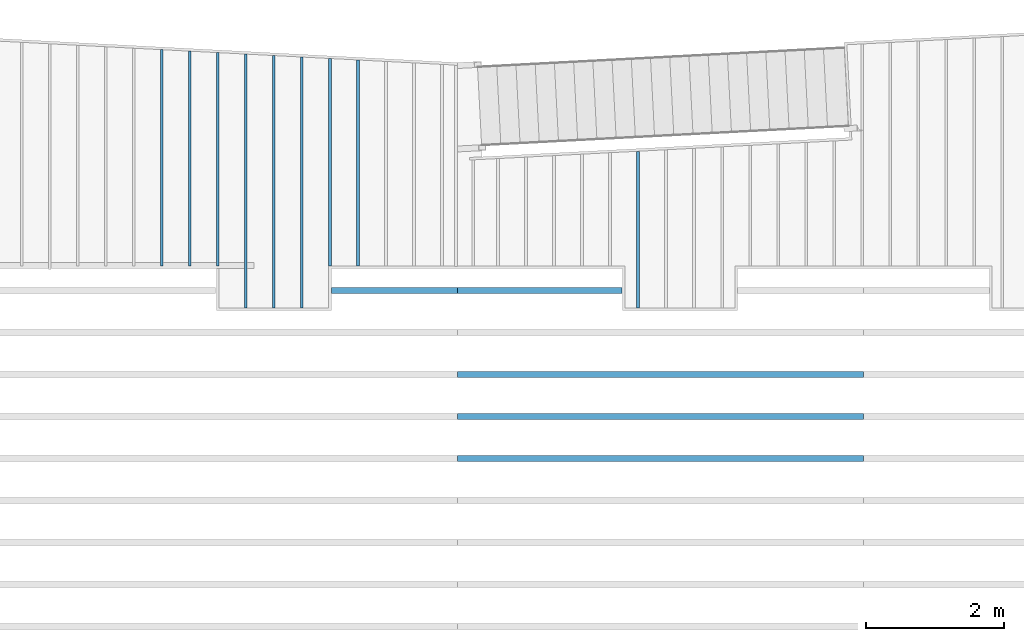
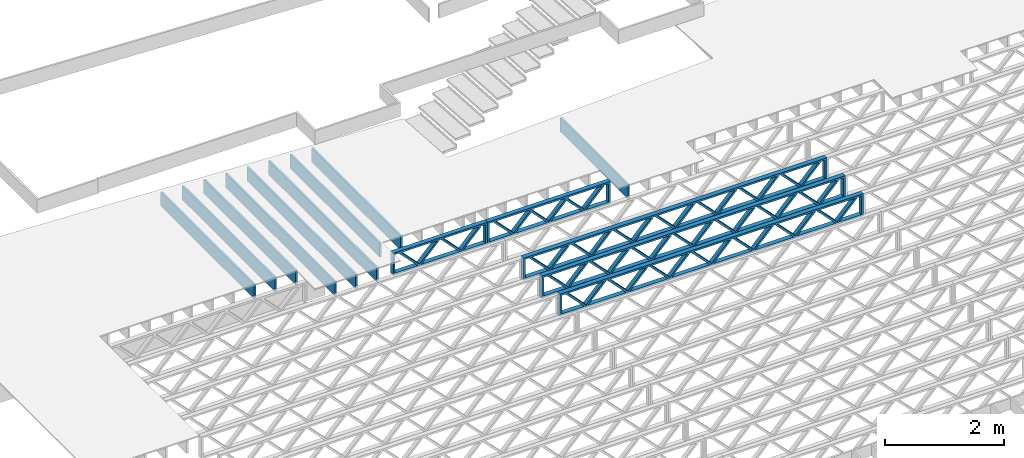
# One storey, part 4 of 23: 14 beams, 3 elements without a shape of their own.
"""IFC4 building model written with IfcOpenShell, lengths in feet."""

import ifcopenshell
import ifcopenshell.guid

model = None  # the IFC model being written
_history = None  # IfcOwnerHistory: only IFC2X3 demands one
_inside = {}  # id of a spatial element -> (the spatial element, [elements in it])
_under = {}  # id of a project, library or spatial element -> (it, [spatial elements below it])
_declared = {}  # id of a project -> (the project, [libraries it declares])
_typed = {}  # id of a type object -> (the type object, [elements of that type])
_made_of = {}  # id of a material, layer set ... -> (it, [elements and type objects made of it])


def new_model(schema):
    """Start an empty IFC model of exactly this schema.

    Asked for "IFC4X3", IfcOpenShell would pick the latest addendum, in which some entities
    have other attributes; the version numbers below select the first issue.
    IFC2X3 requires an IfcOwnerHistory on every rooted entity: one is made here for all.
    """
    global model, _history
    if schema == "IFC4X3":
        model = ifcopenshell.file(schema_version=(4, 3, 0, 0))
    else:
        model = ifcopenshell.file(schema=schema)
    _inside.clear()
    _under.clear()
    _declared.clear()
    _typed.clear()
    _made_of.clear()
    _history = None
    if model.schema == "IFC2X3":
        org = make("IfcOrganization", Name="unknown")
        user = make(
            "IfcPersonAndOrganization",
            ThePerson=make("IfcPerson", FamilyName="unknown"),
            TheOrganization=org,
        )
        app = make(
            "IfcApplication",
            ApplicationDeveloper=org,
            Version="unknown",
            ApplicationFullName="unknown",
            ApplicationIdentifier="unknown",
        )
        _history = make(
            "IfcOwnerHistory",
            OwningUser=user,
            OwningApplication=app,
            ChangeAction="ADDED",
            CreationDate=0,
        )
    return model


def make(cls, **values):
    """One entity of the class cls with the attributes given. An attribute that is None is left unset."""
    return model.create_entity(
        cls, **{name: value for name, value in values.items() if value is not None}
    )


def entity(cls, *values):
    """Any entity or typed value of the class cls, its attributes in the order of the schema. None: left unset."""
    e = model.create_entity(cls)
    for i, value in enumerate(values):
        if value is not None:
            e[i] = value
    return e


def rooted(cls, **values):
    """An entity with a GlobalId (a new one), such as an element, a storey or a relation."""
    return make(cls, GlobalId=ifcopenshell.guid.new(), OwnerHistory=_history, **values)


def si_unit(unit_type, name, prefix=None):
    """IfcSIUnit, for example si_unit("LENGTHUNIT", "METRE", prefix="MILLI")."""
    return make("IfcSIUnit", UnitType=unit_type, Prefix=prefix, Name=name)


def converted_unit(unit_type, name, factor, base, dimensions=None, offset=None):
    """IfcConversionBasedUnit, such as the inch: factor (a typed value) times the base unit."""
    return make(
        "IfcConversionBasedUnit"
        if offset is None
        else "IfcConversionBasedUnitWithOffset",
        ConversionOffset=offset,
        Dimensions=None
        if dimensions is None
        else entity("IfcDimensionalExponents", *dimensions),
        UnitType=unit_type,
        Name=name,
        ConversionFactor=make(
            "IfcMeasureWithUnit", ValueComponent=factor, UnitComponent=base
        ),
    )


def derived_unit(unit_type, elements):
    """IfcDerivedUnit: a product of units, each with its exponent."""
    return make(
        "IfcDerivedUnit",
        Elements=[
            make("IfcDerivedUnitElement", Unit=unit, Exponent=power)
            for unit, power in elements
        ],
        UnitType=unit_type,
    )


def assignment(units):
    """IfcUnitAssignment: the units of a project."""
    return None if units is None else make("IfcUnitAssignment", Units=units)


def point(xyz):
    """IfcCartesianPoint."""
    return None if xyz is None else make("IfcCartesianPoint", Coordinates=xyz)


def direction(xyz):
    """IfcDirection."""
    return None if xyz is None else make("IfcDirection", DirectionRatios=xyz)


def frame(location, z_axis=None, x_axis=None):
    """IfcAxis2Placement3D, a coordinate frame: its origin and axes. An axis left out is left unset."""
    return make(
        "IfcAxis2Placement3D",
        Location=point(location),
        Axis=direction(z_axis),
        RefDirection=direction(x_axis),
    )


def frame_2d(location, x_axis=None):
    """IfcAxis2Placement2D, a coordinate frame in the plane: its origin and x axis."""
    return make(
        "IfcAxis2Placement2D", Location=point(location), RefDirection=direction(x_axis)
    )


def origin():
    """The frame at (0, 0, 0) with its axes left unset."""
    return frame((0.0, 0.0, 0.0))


def origin_2d_with_axis():
    """The frame at (0, 0) in the plane with the x axis (1, 0) written out."""
    return frame_2d((0.0, 0.0), x_axis=(1.0, 0.0))


def place(relative_to, where):
    """IfcLocalPlacement: puts the frame where relative to a parent placement (None: the world)."""
    return make(
        "IfcLocalPlacement", PlacementRelTo=relative_to, RelativePlacement=where
    )


def context(
    kind, dimensions, precision=None, world=None, true_north=None, identifier=None
):
    """IfcGeometricRepresentationContext, for example the 3D "Model" context."""
    return make(
        "IfcGeometricRepresentationContext",
        ContextIdentifier=identifier,
        ContextType=kind,
        CoordinateSpaceDimension=dimensions,
        Precision=precision,
        WorldCoordinateSystem=world,
        TrueNorth=true_north,
    )


def subcontext(parent, identifier, kind, view, scale=None):
    """IfcGeometricRepresentationSubContext, for example "Body" below "Model"."""
    return make(
        "IfcGeometricRepresentationSubContext",
        ContextIdentifier=identifier,
        ContextType=kind,
        ParentContext=parent,
        TargetScale=scale,
        TargetView=view,
    )


def project(units=None, contexts=None):
    """IfcProject with its units and contexts."""
    return rooted(
        "IfcProject",
        Name="project",
        RepresentationContexts=contexts,
        UnitsInContext=assignment(units),
    )


def spatial(cls, under=None, at=None, **own):
    """A site, building, storey or space (cls), placed at a placement, below another one or the project."""
    s = rooted(cls, ObjectPlacement=at, **own)
    if under is not None:
        _under.setdefault(under.id(), (under, []))[1].append(s)
    return s


def profile(cls, at=None, kind="AREA", **sizes):
    """A parametric profile (cls). Its sizes go by their IFC names, for example OverallWidth=200.0."""
    return make(cls, ProfileType=kind, Position=at, **sizes)


def rectangle(**sizes):
    """IfcRectangleProfileDef."""
    return profile("IfcRectangleProfileDef", **sizes)


def extrude(swept, where, along, depth):
    """IfcExtrudedAreaSolid: the profile swept, set in the frame where, extruded along a direction by depth."""
    return make(
        "IfcExtrudedAreaSolid",
        SweptArea=swept,
        Position=where,
        ExtrudedDirection=direction(along),
        Depth=depth,
    )


def shape(context_of_items, identifier, shape_type, items):
    """IfcShapeRepresentation: the items that make up one representation, for example the "Body"."""
    return make(
        "IfcShapeRepresentation",
        ContextOfItems=context_of_items,
        RepresentationIdentifier=identifier,
        RepresentationType=shape_type,
        Items=items,
    )


def source(mapping_origin, context_of_items, identifier, shape_type, items):
    """IfcRepresentationMap: a shape defined once, which mapped items show again and again."""
    return make(
        "IfcRepresentationMap",
        MappingOrigin=mapping_origin,
        MappedRepresentation=shape(context_of_items, identifier, shape_type, items),
    )


def transform(
    local_origin,
    x_axis=None,
    y_axis=None,
    z_axis=None,
    scale=None,
    scale2=None,
    scale3=None,
    uniform=True,
):
    """IfcCartesianTransformationOperator3D, or its non-uniform kind. x_axis, y_axis, z_axis: its Axis1, 2, 3."""
    if uniform:
        return make(
            "IfcCartesianTransformationOperator3D",
            Axis1=direction(x_axis),
            Axis2=direction(y_axis),
            LocalOrigin=point(local_origin),
            Scale=scale,
            Axis3=direction(z_axis),
        )
    return make(
        "IfcCartesianTransformationOperator3DnonUniform",
        Axis1=direction(x_axis),
        Axis2=direction(y_axis),
        LocalOrigin=point(local_origin),
        Scale=scale,
        Axis3=direction(z_axis),
        Scale2=scale2,
        Scale3=scale3,
    )


def mapped(mapping_source, mapping_target):
    """IfcMappedItem: shows the shape of a source again, moved by a transform."""
    return make(
        "IfcMappedItem", MappingSource=mapping_source, MappingTarget=mapping_target
    )


def material(Name=None, Category=None):
    """IfcMaterial."""
    return make("IfcMaterial", Name=Name, Category=Category)


def material_profile(
    of_material, cross_section, Name=None, Category=None, Priority=None
):
    """IfcMaterialProfile: a cross section and its material."""
    return make(
        "IfcMaterialProfile",
        Name=Name,
        Material=of_material,
        Profile=cross_section,
        Priority=Priority,
        Category=Category,
    )


def profile_set(profiles, Name=None, composite=None):
    """IfcMaterialProfileSet."""
    return make(
        "IfcMaterialProfileSet",
        Name=Name,
        MaterialProfiles=profiles,
        CompositeProfile=composite,
    )


def profile_usage(for_profile_set, cardinal=None, extent=None):
    """IfcMaterialProfileSetUsage: how a profile set lies along its element."""
    return make(
        "IfcMaterialProfileSetUsage",
        ForProfileSet=for_profile_set,
        CardinalPoint=cardinal,
        ReferenceExtent=extent,
    )


def made_of(thing, what):
    """Note that an element or type object is made of a material, layer set ...; save() writes the relation."""
    if what is not None:
        _made_of.setdefault(what.id(), (what, []))[1].append(thing)
    return thing


def type_object(cls, material=None, **own):
    """A type object (cls), such as IfcWallType, which elements share."""
    return made_of(rooted(cls, **own), material)


def type_shapes(of_type, sources):
    """Give a type object the sources (RepresentationMaps) that its elements show as mapped items."""
    of_type.RepresentationMaps = sources


def element(
    cls,
    number,
    at=None,
    inside=None,
    cuts=None,
    type_object=None,
    material=None,
    context=None,
    identifier="Body",
    shape_type=None,
    held_by="IfcProductDefinitionShape",
    body=None,
    shapes=None,
    **own,
):
    """One element of the class cls, such as IfcWall. Its Tag is "e" and its number.

    at: its placement. inside: the storey or other place that contains it. cuts: it is an
    opening in that element (IfcRelVoidsElement). A single representation is given by context,
    identifier, shape_type and body (its items); several are given by shapes. held_by: the class
    of the entity that holds the representations. save() writes the other relations.
    """
    e = rooted(cls, Tag="e%d" % number, ObjectPlacement=at, **own)
    if body is not None:
        shapes = [shape(context, identifier, shape_type, body)]
    if shapes is not None:
        e.Representation = make(held_by, Representations=shapes)
    if inside is not None:
        _inside.setdefault(inside.id(), (inside, []))[1].append(e)
    if cuts is not None:
        rooted(
            "IfcRelVoidsElement", RelatingBuildingElement=cuts, RelatedOpeningElement=e
        )
    if type_object is not None:
        _typed.setdefault(type_object.id(), (type_object, []))[1].append(e)
    return made_of(e, material)


def aggregate(whole, parts):
    """IfcRelAggregates: a whole, such as a stair, and the parts it consists of."""
    return rooted("IfcRelAggregates", RelatingObject=whole, RelatedObjects=parts)


def save(model, path):
    """Write the relations noted so far, then the file.

    IfcRelAggregates (storeys below a building ...), IfcRelContainedInSpatialStructure (elements
    in a storey), IfcRelDefinesByType, IfcRelAssociatesMaterial and IfcRelDeclares: one each for
    every whole, place, type object, material and project.
    """
    for whole, parts in _under.values():
        aggregate(whole, parts)
    for where, things in _inside.values():
        rooted(
            "IfcRelContainedInSpatialStructure",
            RelatedElements=things,
            RelatingStructure=where,
        )
    for kind, things in _typed.values():
        rooted("IfcRelDefinesByType", RelatedObjects=things, RelatingType=kind)
    for what, things in _made_of.values():
        rooted("IfcRelAssociatesMaterial", RelatedObjects=things, RelatingMaterial=what)
    for by, libraries in _declared.values():
        rooted("IfcRelDeclares", RelatingContext=by, RelatedDefinitions=libraries)
    model.write(path)


model = new_model("IFC4")

# Units and contexts
model_context = context("Model", 3, precision=0.0001, world=origin(), true_north=direction((6.12303176911189e-17, 1.0)))
body_context = subcontext(model_context, "Body", "Model", "MODEL_VIEW")
ifc_project = project(units=[converted_unit("LENGTHUNIT", "FOOT", entity("IfcRatioMeasure", 0.3048), si_unit("LENGTHUNIT", "METRE"), dimensions=[1, 0, 0, 0, 0, 0, 0]), converted_unit("AREAUNIT", "SQUARE FOOT", entity("IfcRatioMeasure", 0.09290304), si_unit("AREAUNIT", "SQUARE_METRE"), dimensions=[2, 0, 0, 0, 0, 0, 0]), converted_unit("VOLUMEUNIT", "CUBIC FOOT", entity("IfcRatioMeasure", 0.028316846592), si_unit("VOLUMEUNIT", "CUBIC_METRE"), dimensions=[3, 0, 0, 0, 0, 0, 0]), converted_unit("PLANEANGLEUNIT", "DEGREE", entity("IfcRatioMeasure", 0.0174532925199433), si_unit("PLANEANGLEUNIT", "RADIAN"), dimensions=[0, 0, 0, 0, 0, 0, 0]), si_unit("MASSUNIT", "GRAM", prefix="KILO"), derived_unit("MASSDENSITYUNIT", [(si_unit("MASSUNIT", "GRAM", prefix="KILO"), 1), (si_unit("LENGTHUNIT", "METRE"), -3)]), derived_unit("MOMENTOFINERTIAUNIT", [(si_unit("LENGTHUNIT", "METRE"), 4)]), si_unit("TIMEUNIT", "SECOND"), si_unit("FREQUENCYUNIT", "HERTZ"), si_unit("THERMODYNAMICTEMPERATUREUNIT", "DEGREE_CELSIUS"), derived_unit("THERMALTRANSMITTANCEUNIT", [(si_unit("MASSUNIT", "GRAM", prefix="KILO"), 1), (si_unit("THERMODYNAMICTEMPERATUREUNIT", "KELVIN"), -1), (si_unit("TIMEUNIT", "SECOND"), -3)]), derived_unit("VOLUMETRICFLOWRATEUNIT", [(si_unit("LENGTHUNIT", "METRE"), 3), (si_unit("TIMEUNIT", "SECOND"), -1)]), si_unit("ELECTRICCURRENTUNIT", "AMPERE"), si_unit("ELECTRICVOLTAGEUNIT", "VOLT"), si_unit("POWERUNIT", "WATT"), si_unit("FORCEUNIT", "NEWTON"), si_unit("ILLUMINANCEUNIT", "LUX"), si_unit("LUMINOUSFLUXUNIT", "LUMEN"), si_unit("LUMINOUSINTENSITYUNIT", "CANDELA"), derived_unit("USERDEFINED", [(si_unit("MASSUNIT", "GRAM", prefix="KILO"), -1), (si_unit("LENGTHUNIT", "METRE"), -2), (si_unit("TIMEUNIT", "SECOND"), 3), (si_unit("LUMINOUSFLUXUNIT", "LUMEN"), 1)]), derived_unit("LINEARVELOCITYUNIT", [(si_unit("LENGTHUNIT", "METRE"), 1), (si_unit("TIMEUNIT", "SECOND"), -1)]), si_unit("PRESSUREUNIT", "PASCAL"), derived_unit("USERDEFINED", [(si_unit("LENGTHUNIT", "METRE"), -2), (si_unit("MASSUNIT", "GRAM", prefix="KILO"), 1), (si_unit("TIMEUNIT", "SECOND"), -2)]), derived_unit("LINEARFORCEUNIT", [(si_unit("MASSUNIT", "GRAM", prefix="KILO"), 1), (si_unit("LENGTHUNIT", "METRE"), 1), (si_unit("TIMEUNIT", "SECOND"), -2), (si_unit("LENGTHUNIT", "METRE"), -1)]), derived_unit("PLANARFORCEUNIT", [(si_unit("MASSUNIT", "GRAM", prefix="KILO"), 1), (si_unit("LENGTHUNIT", "METRE"), 1), (si_unit("TIMEUNIT", "SECOND"), -2), (si_unit("LENGTHUNIT", "METRE"), -2)])], contexts=[model_context])

# Site, building, storey
site_placement = place(None, origin())
site = spatial("IfcSite", under=ifc_project, at=site_placement, CompositionType="ELEMENT")
building_placement = place(site_placement, origin())
building = spatial("IfcBuilding", under=site, at=building_placement, CompositionType="ELEMENT")
storey_placement = place(building_placement, frame((0.0, 0.0, 10.8020833333333)))
storey = spatial("IfcBuildingStorey", under=building, at=storey_placement, Name="2ND FLOOR", CompositionType="ELEMENT", Elevation=10.8020833333333)

# Assembly, beam
assembly_1_placement = place(storey_placement, origin())
assembly_1 = element("IfcElementAssembly", 1, at=assembly_1_placement, inside=storey, Name="Structural Beam System:Structural Framing System", ObjectType="Structural Beam System:Structural Framing System", AssemblyPlace="NOTDEFINED", PredefinedType="BEAM_GRID")
ifc_material_1 = material(Name="WOOD TRUSS", Category="Materials")
ifc_material_profile_1 = material_profile(ifc_material_1, rectangle(XDim=1.73473973950632, YDim=0.125, at=frame_2d((-1.11022302462516e-16, 8.32667268468867e-17), x_axis=(1.0, 0.0))))
ifc_material_profile_2 = material_profile(ifc_material_1, rectangle(XDim=1.73473973950633, YDim=0.125, at=frame_2d((-1.11022302462516e-16, 8.32667268468867e-17), x_axis=(1.0, 0.0))))
ifc_material_profile_3 = material_profile(ifc_material_1, rectangle(XDim=1.73473973950632, YDim=0.125, at=frame_2d((-5.55111512312578e-17, 1.38777878078145e-16), x_axis=(1.0, 0.0))))
ifc_material_profile_4 = material_profile(ifc_material_1, rectangle(XDim=1.73473973950633, YDim=0.125, at=frame_2d((-1.11022302462516e-16, 8.32667268468867e-17), x_axis=(1.0, 0.0))))
ifc_material_profile_5 = material_profile(ifc_material_1, rectangle(XDim=1.73473973950632, YDim=0.125, at=frame_2d((-1.11022302462516e-16, 8.32667268468867e-17), x_axis=(1.0, 0.0))))
ifc_material_profile_6 = material_profile(ifc_material_1, rectangle(XDim=1.73473973950633, YDim=0.125, at=frame_2d((-2.77555756156289e-16, 3.05311331771918e-16), x_axis=(1.0, 0.0))))
ifc_material_profile_7 = material_profile(ifc_material_1, rectangle(XDim=1.73473973950632, YDim=0.124999999999999, at=frame_2d((-3.88578058618805e-16, -2.4980018054066e-16), x_axis=(1.0, 0.0))))
ifc_material_profile_8 = material_profile(ifc_material_1, rectangle(XDim=1.73473973950633, YDim=0.125, at=frame_2d((2.77555756156289e-16, -3.05311331771918e-16), x_axis=(1.0, 0.0))))
ifc_material_profile_9 = material_profile(ifc_material_1, rectangle(XDim=1.73473973950632, YDim=0.124999999999999, at=frame_2d((-1.11022302462516e-16, 8.32667268468867e-17), x_axis=(1.0, 0.0))))
ifc_material_profile_10 = material_profile(ifc_material_1, rectangle(XDim=1.73473973950633, YDim=0.125, at=origin_2d_with_axis()))
ifc_material_profile_11 = material_profile(ifc_material_1, rectangle(XDim=0.124999999999982, YDim=0.291666666666668, at=origin_2d_with_axis()))
ifc_material_profile_12 = material_profile(ifc_material_1, rectangle(XDim=0.124999999999932, YDim=0.291666666666664, at=origin_2d_with_axis()))
ifc_material_profile_13 = material_profile(ifc_material_1, rectangle(XDim=1.25000000000002, YDim=0.29166666666667, at=origin_2d_with_axis()))
ifc_material_profile_14 = material_profile(ifc_material_1, rectangle(XDim=1.25000000000004, YDim=0.291666666666667, at=origin_2d_with_axis()))
ifc_profile_set_1 = profile_set([ifc_material_profile_1, ifc_material_profile_2, ifc_material_profile_3, ifc_material_profile_4, ifc_material_profile_5, ifc_material_profile_6, ifc_material_profile_7, ifc_material_profile_8, ifc_material_profile_9, ifc_material_profile_10, ifc_material_profile_11, ifc_material_profile_12, ifc_material_profile_13, ifc_material_profile_14])
ifc_profile_usage_1 = profile_usage(ifc_profile_set_1, cardinal=8)
beam_type_1 = type_object("IfcBeamType", PredefinedType="BEAM", material=ifc_profile_set_1)
shared_shape_1 = source(origin(), body_context, "Body", "SweptSolid", [
    extrude(rectangle(XDim=1.73473973950632, YDim=0.125, at=frame_2d((0.0, 1.66533453693773e-16), x_axis=(1.0, 0.0))), frame((1.95847576769603, -0.145833333333334, 0.0), z_axis=(0.0, 1.0, 0.0), x_axis=(0.693383046997606, 0.0, 0.720569184836762)), (0.0, 0.0, 1.0), 0.291666666666667),
    extrude(rectangle(XDim=1.73473973950633, YDim=0.125, at=frame_2d((-5.55111512312578e-17, 8.32667268468867e-17), x_axis=(1.0, 0.0))), frame((0.708189894022761, -0.145833333333334, 0.0), z_axis=(0.0, 1.0, 0.0), x_axis=(0.69338304699761, 0.0, -0.720569184836758)), (0.0, 0.0, 1.0), 0.291666666666667),
    extrude(rectangle(XDim=1.73473973950632, YDim=0.125, at=frame_2d((0.0, 1.66533453693773e-16), x_axis=(1.0, 0.0))), frame((-0.708189894022106, -0.145833333333334, 0.0), z_axis=(0.0, 1.0, 0.0), x_axis=(0.693383046997606, 0.0, 0.720569184836762)), (0.0, 0.0, 1.0), 0.291666666666667),
    extrude(rectangle(XDim=1.73473973950633, YDim=0.125, at=frame_2d((-2.22044604925031e-16, 2.22044604925031e-16), x_axis=(1.0, 0.0))), frame((-1.95847576769538, -0.145833333333334, 0.0), z_axis=(0.0, 1.0, 0.0), x_axis=(0.69338304699761, 0.0, -0.720569184836758)), (0.0, 0.0, 1.0), 0.291666666666666),
    extrude(rectangle(XDim=0.124999999999982, YDim=0.291666666666668, at=origin_2d_with_axis()), frame((-2.99999949752565, 0.0, 0.687500000000054), z_axis=(1.0, 0.0, 0.0), x_axis=(0.0, 0.0, -1.0)), (0.0, 0.0, 1.0), 5.9999989950513),
    extrude(rectangle(XDim=0.124999999999932, YDim=0.291666666666664, at=origin_2d_with_axis()), frame((-2.99999949752544, 0.0, -0.687499999999984), z_axis=(1.0, 0.0, 0.0), x_axis=(0.0, 0.0, -1.0)), (0.0, 0.0, 1.0), 5.99999899505109),
    extrude(rectangle(XDim=1.25000000000002, YDim=0.29166666666667, at=origin_2d_with_axis()), frame((2.87499949752563, 0.0, 0.0), z_axis=(1.0, 0.0, 0.0), x_axis=(0.0, 0.0, -1.0)), (0.0, 0.0, 1.0), 0.12500000000002),
    extrude(rectangle(XDim=1.25000000000004, YDim=0.291666666666667, at=origin_2d_with_axis()), frame((-2.99999949752565, 0.0, 0.0), z_axis=(1.0, 0.0, 0.0), x_axis=(0.0, 0.0, -1.0)), (0.0, 0.0, 1.0), 0.125000000000023),
])
type_shapes(beam_type_1, [shared_shape_1])
beam_1_placement = place(assembly_1_placement, frame((-244.738160011261, 957.861934882651, -0.947916666657848)))
beam_1 = element("IfcBeam", 2, at=beam_1_placement, type_object=beam_type_1, material=ifc_profile_usage_1, PredefinedType="BEAM", context=body_context, shape_type="MappedRepresentation", body=[
    mapped(shared_shape_1, transform((0.0, 0.0, 0.0), scale=1.0)),
])
aggregate(assembly_1, [beam_1])

# Assembly, beams
assembly_2_placement = place(storey_placement, origin())
assembly_2 = element("IfcElementAssembly", 3, at=assembly_2_placement, inside=storey, Name="Structural Beam System:Structural Framing System", ObjectType="Structural Beam System:Structural Framing System", AssemblyPlace="NOTDEFINED", PredefinedType="BEAM_GRID")
ifc_profile_usage_2 = profile_usage(ifc_profile_set_1, cardinal=8)
beam_type_2 = type_object("IfcBeamType", PredefinedType="BEAM", material=ifc_profile_set_1)
shared_shape_2 = source(origin(), body_context, "Body", "SweptSolid", [
    extrude(rectangle(XDim=1.73473973950632, YDim=0.125, at=frame_2d((-5.55111512312578e-17, 1.38777878078145e-16), x_axis=(1.0, 0.0))), frame((0.625142936836962, -0.145833333333334, 0.0), z_axis=(0.0, 1.0, 0.0), x_axis=(0.693383046997606, 0.0, 0.720569184836762)), (0.0, 0.0, 1.0), 0.291666666666667),
    extrude(rectangle(XDim=1.73473973950633, YDim=0.125, at=frame_2d((-1.11022302462516e-16, 8.32667268468867e-17), x_axis=(1.0, 0.0))), frame((-0.625142936836309, -0.145833333333334, 0.0), z_axis=(0.0, 1.0, 0.0), x_axis=(0.69338304699761, 0.0, -0.720569184836758)), (0.0, 0.0, 1.0), 0.291666666666667),
    extrude(rectangle(XDim=1.73473973950632, YDim=0.125, at=frame_2d((-1.11022302462516e-16, 8.32667268468867e-17), x_axis=(1.0, 0.0))), frame((2.87514283803796, -0.145833333333334, 0.0), z_axis=(0.0, 1.0, 0.0), x_axis=(0.693383046997606, 0.0, 0.720569184836762)), (0.0, 0.0, 1.0), 0.291666666666667),
    extrude(rectangle(XDim=1.73473973950633, YDim=0.125, at=frame_2d((-1.11022302462516e-16, 8.32667268468867e-17), x_axis=(1.0, 0.0))), frame((1.62485696436469, -0.145833333333334, 0.0), z_axis=(0.0, 1.0, 0.0), x_axis=(0.69338304699761, 0.0, -0.720569184836758)), (0.0, 0.0, 1.0), 0.291666666666667),
    extrude(rectangle(XDim=1.73473973950632, YDim=0.125, at=frame_2d((-1.11022302462516e-16, 8.32667268468867e-17), x_axis=(1.0, 0.0))), frame((-1.62485696436403, -0.145833333333334, 0.0), z_axis=(0.0, 1.0, 0.0), x_axis=(0.693383046997606, 0.0, 0.720569184836762)), (0.0, 0.0, 1.0), 0.291666666666667),
    extrude(rectangle(XDim=1.73473973950633, YDim=0.125, at=origin_2d_with_axis()), frame((-2.87514283803731, -0.145833333333334, 0.0), z_axis=(0.0, 1.0, 0.0), x_axis=(0.69338304699761, 0.0, -0.720569184836758)), (0.0, 0.0, 1.0), 0.291666666666667),
    extrude(rectangle(XDim=0.124999999999982, YDim=0.291666666666668, at=origin_2d_with_axis()), frame((-3.91666656786758, 0.0, 0.687500000000054), z_axis=(1.0, 0.0, 0.0), x_axis=(0.0, 0.0, -1.0)), (0.0, 0.0, 1.0), 7.83333313573516),
    extrude(rectangle(XDim=0.124999999999932, YDim=0.291666666666664, at=origin_2d_with_axis()), frame((-3.91666656786737, 0.0, -0.687499999999984), z_axis=(1.0, 0.0, 0.0), x_axis=(0.0, 0.0, -1.0)), (0.0, 0.0, 1.0), 7.83333313573495),
    extrude(rectangle(XDim=1.25000000000002, YDim=0.29166666666667, at=origin_2d_with_axis()), frame((3.79166656786756, 0.0, 0.0), z_axis=(1.0, 0.0, 0.0), x_axis=(0.0, 0.0, -1.0)), (0.0, 0.0, 1.0), 0.12500000000002),
    extrude(rectangle(XDim=1.25000000000004, YDim=0.291666666666667, at=origin_2d_with_axis()), frame((-3.91666656786758, 0.0, 0.0), z_axis=(1.0, 0.0, 0.0), x_axis=(0.0, 0.0, -1.0)), (0.0, 0.0, 1.0), 0.125000000000023),
])
type_shapes(beam_type_2, [shared_shape_2])
beam_2_placement = place(assembly_2_placement, frame((-237.821493887522, 957.861934882651, -0.947916666666657)))
beam_2 = element("IfcBeam", 4, at=beam_2_placement, type_object=beam_type_2, material=ifc_profile_usage_2, PredefinedType="BEAM", context=body_context, shape_type="MappedRepresentation", body=[
    mapped(shared_shape_2, transform((0.0, 0.0, 0.0), scale=1.0)),
])
ifc_profile_usage_3 = profile_usage(ifc_profile_set_1, cardinal=8)
beam_type_3 = type_object("IfcBeamType", PredefinedType="BEAM", material=ifc_profile_set_1)
shared_shape_3 = source(origin(), body_context, "Body", "SweptSolid", [
    extrude(rectangle(XDim=1.73473973950632, YDim=0.124999999999999, at=frame_2d((5.55111512312578e-16, 7.21644966006352e-16), x_axis=(1.0, 0.0))), frame((5.95847627016997, -0.145833333333334, 0.0), z_axis=(0.0, 1.0, 0.0), x_axis=(0.693383046997606, 0.0, 0.720569184836762)), (0.0, 0.0, 1.0), 0.291666666666667),
    extrude(rectangle(XDim=1.73473973950633, YDim=0.125, at=origin_2d_with_axis()), frame((4.7081903964967, -0.145833333333334, 0.0), z_axis=(0.0, 1.0, 0.0), x_axis=(0.69338304699761, 0.0, -0.720569184836758)), (0.0, 0.0, 1.0), 0.291666666666666),
    extrude(rectangle(XDim=1.73473973950632, YDim=0.125, at=frame_2d((2.22044604925031e-16, 3.88578058618805e-16), x_axis=(1.0, 0.0))), frame((3.29180960350347, -0.145833333333334, 0.0), z_axis=(0.0, 1.0, 0.0), x_axis=(0.693383046997606, 0.0, 0.720569184836762)), (0.0, 0.0, 1.0), 0.291666666666667),
    extrude(rectangle(XDim=1.73473973950633, YDim=0.125, at=frame_2d((1.11022302462516e-16, -8.32667268468867e-17), x_axis=(1.0, 0.0))), frame((2.0415237298302, -0.145833333333334, 0.0), z_axis=(0.0, 1.0, 0.0), x_axis=(0.69338304699761, 0.0, -0.720569184836758)), (0.0, 0.0, 1.0), 0.291666666666667),
    extrude(rectangle(XDim=1.73473973950632, YDim=0.125, at=frame_2d((-5.55111512312578e-17, 1.38777878078145e-16), x_axis=(1.0, 0.0))), frame((0.625142936836964, -0.145833333333334, 0.0), z_axis=(0.0, 1.0, 0.0), x_axis=(0.693383046997606, 0.0, 0.720569184836762)), (0.0, 0.0, 1.0), 0.291666666666667),
    extrude(rectangle(XDim=1.73473973950633, YDim=0.125, at=frame_2d((-1.11022302462516e-16, 8.32667268468867e-17), x_axis=(1.0, 0.0))), frame((-0.625142936836306, -0.145833333333334, 0.0), z_axis=(0.0, 1.0, 0.0), x_axis=(0.69338304699761, 0.0, -0.720569184836758)), (0.0, 0.0, 1.0), 0.291666666666667),
    extrude(rectangle(XDim=1.73473973950632, YDim=0.125, at=frame_2d((-1.11022302462516e-16, 8.32667268468867e-17), x_axis=(1.0, 0.0))), frame((-2.04152372982954, -0.145833333333334, 0.0), z_axis=(0.0, 1.0, 0.0), x_axis=(0.693383046997606, 0.0, 0.720569184836762)), (0.0, 0.0, 1.0), 0.291666666666667),
    extrude(rectangle(XDim=1.73473973950633, YDim=0.125, at=origin_2d_with_axis()), frame((-3.29180960350281, -0.145833333333334, 0.0), z_axis=(0.0, 1.0, 0.0), x_axis=(0.69338304699761, 0.0, -0.720569184836758)), (0.0, 0.0, 1.0), 0.291666666666667),
    extrude(rectangle(XDim=1.73473973950632, YDim=0.124999999999999, at=frame_2d((-1.11022302462516e-16, 8.32667268468867e-17), x_axis=(1.0, 0.0))), frame((-4.70819039649604, -0.145833333333334, 0.0), z_axis=(0.0, 1.0, 0.0), x_axis=(0.693383046997606, 0.0, 0.720569184836762)), (0.0, 0.0, 1.0), 0.291666666666667),
    extrude(rectangle(XDim=1.73473973950633, YDim=0.125, at=frame_2d((-5.55111512312578e-16, 6.38378239159465e-16), x_axis=(1.0, 0.0))), frame((-5.95847627016931, -0.145833333333334, 0.0), z_axis=(0.0, 1.0, 0.0), x_axis=(0.69338304699761, 0.0, -0.720569184836758)), (0.0, 0.0, 1.0), 0.291666666666666),
    extrude(rectangle(XDim=1.73473973950632, YDim=0.125, at=frame_2d((-7.21644966006352e-16, -5.82867087928207e-16), x_axis=(1.0, 0.0))), frame((8.62514293683647, -0.145833333333334, 0.0), z_axis=(0.0, 1.0, 0.0), x_axis=(0.693383046997607, 0.0, 0.720569184836761)), (0.0, 0.0, 1.0), 0.291666666666667),
    extrude(rectangle(XDim=1.73473973950633, YDim=0.125, at=origin_2d_with_axis()), frame((7.3748570631632, -0.145833333333334, 0.0), z_axis=(0.0, 1.0, 0.0), x_axis=(0.69338304699761, 0.0, -0.720569184836758)), (0.0, 0.0, 1.0), 0.291666666666666),
    extrude(rectangle(XDim=1.73473973950632, YDim=0.124999999999999, at=frame_2d((-1.11022302462516e-16, 8.32667268468867e-17), x_axis=(1.0, 0.0))), frame((-7.37485706316255, -0.145833333333334, 0.0), z_axis=(0.0, 1.0, 0.0), x_axis=(0.693383046997606, 0.0, 0.720569184836762)), (0.0, 0.0, 1.0), 0.291666666666667),
    extrude(rectangle(XDim=1.73473973950633, YDim=0.125, at=origin_2d_with_axis()), frame((-8.62514293683582, -0.145833333333334, 0.0), z_axis=(0.0, 1.0, 0.0), x_axis=(0.69338304699761, 0.0, -0.720569184836758)), (0.0, 0.0, 1.0), 0.291666666666666),
    extrude(rectangle(XDim=0.124999999999982, YDim=0.291666666666668, at=origin_2d_with_axis()), frame((-9.66666666666609, 0.0, 0.687500000000054), z_axis=(1.0, 0.0, 0.0), x_axis=(0.0, 0.0, -1.0)), (0.0, 0.0, 1.0), 19.3333333333322),
    extrude(rectangle(XDim=0.124999999999932, YDim=0.291666666666664, at=origin_2d_with_axis()), frame((-9.66666666666588, 0.0, -0.687499999999984), z_axis=(1.0, 0.0, 0.0), x_axis=(0.0, 0.0, -1.0)), (0.0, 0.0, 1.0), 19.333333333332),
    extrude(rectangle(XDim=1.25000000000002, YDim=0.29166666666667, at=origin_2d_with_axis()), frame((9.54166666666607, 0.0, 0.0), z_axis=(1.0, 0.0, 0.0), x_axis=(0.0, 0.0, -1.0)), (0.0, 0.0, 1.0), 0.12500000000002),
    extrude(rectangle(XDim=1.25000000000004, YDim=0.291666666666667, at=origin_2d_with_axis()), frame((-9.66666666666609, 0.0, 0.0), z_axis=(1.0, 0.0, 0.0), x_axis=(0.0, 0.0, -1.0)), (0.0, 0.0, 1.0), 0.125000000000023),
])
type_shapes(beam_type_3, [shared_shape_3])
beam_3_placement = place(assembly_2_placement, frame((-232.071493788723, 953.861934882651, -0.947916666666657)))
beam_3 = element("IfcBeam", 5, at=beam_3_placement, type_object=beam_type_3, material=ifc_profile_usage_3, PredefinedType="BEAM", context=body_context, shape_type="MappedRepresentation", body=[
    mapped(shared_shape_3, transform((0.0, 0.0, 0.0), scale=1.0)),
])
ifc_profile_usage_4 = profile_usage(ifc_profile_set_1, cardinal=8)
beam_4_placement = place(assembly_2_placement, frame((-232.071493788723, 951.861934882651, -0.947916666666657)))
beam_4 = element("IfcBeam", 6, at=beam_4_placement, type_object=beam_type_3, material=ifc_profile_usage_4, PredefinedType="BEAM", context=body_context, shape_type="MappedRepresentation", body=[
    mapped(shared_shape_3, transform((0.0, 0.0, 0.0), scale=1.0)),
])
ifc_profile_usage_5 = profile_usage(ifc_profile_set_1, cardinal=8)
beam_5_placement = place(assembly_2_placement, frame((-232.071493788723, 949.861934882651, -0.947916666666657)))
beam_5 = element("IfcBeam", 7, at=beam_5_placement, type_object=beam_type_3, material=ifc_profile_usage_5, PredefinedType="BEAM", context=body_context, shape_type="MappedRepresentation", body=[
    mapped(shared_shape_3, transform((0.0, 0.0, 0.0), scale=1.0)),
])
aggregate(assembly_2, [beam_2, beam_3, beam_4, beam_5])

assembly_3_placement = place(storey_placement, origin())
assembly_3 = element("IfcElementAssembly", 8, at=assembly_3_placement, inside=storey, Name="Structural Beam System:Structural Framing System", ObjectType="Structural Beam System:Structural Framing System", AssemblyPlace="NOTDEFINED", PredefinedType="BEAM_GRID")
ifc_material_2 = material(Category="Materials")
ifc_material_profile_15 = material_profile(ifc_material_2, rectangle(XDim=0.9375, YDim=0.125000000000011, at=origin_2d_with_axis()))
ifc_profile_set_2 = profile_set([ifc_material_profile_15])
ifc_profile_usage_6 = profile_usage(ifc_profile_set_2, cardinal=8)
beam_type_4 = type_object("IfcBeamType", PredefinedType="BEAM", material=ifc_profile_set_2)
shared_shape_4 = source(origin(), body_context, "Body", "SweptSolid", [
    extrude(rectangle(XDim=0.9375, YDim=0.125000000000011, at=origin_2d_with_axis()), frame((-5.14581317654694, 0.0, 0.0), z_axis=(1.0, 0.0, 0.0), x_axis=(0.0, 0.0, -1.0)), (0.0, 0.0, 1.0), 10.2916263530939),
])
type_shapes(beam_type_4, [shared_shape_4])
beam_6_placement = place(assembly_3_placement, frame((-255.800660485462, 964.174417346213, -0.729166666666744), z_axis=(0.0, 0.0, 1.0), x_axis=(0.0, 1.0, 0.0)))
beam_6 = element("IfcBeam", 9, at=beam_6_placement, type_object=beam_type_4, material=ifc_profile_usage_6, PredefinedType="BEAM", context=body_context, shape_type="MappedRepresentation", body=[
    mapped(shared_shape_4, transform((0.0, 0.0, 0.0), scale=1.0)),
])
ifc_profile_usage_7 = profile_usage(ifc_profile_set_2, cardinal=8)
beam_type_5 = type_object("IfcBeamType", PredefinedType="BEAM", material=ifc_profile_set_2)
shared_shape_5 = source(origin(), body_context, "Body", "SweptSolid", [
    extrude(rectangle(XDim=0.9375, YDim=0.125000000000011, at=origin_2d_with_axis()), frame((-5.11087465702491, 0.0, 0.0), z_axis=(1.0, 0.0, 0.0), x_axis=(0.0, 0.0, -1.0)), (0.0, 0.0, 1.0), 10.2217493140498),
])
type_shapes(beam_type_5, [shared_shape_5])
beam_7_placement = place(assembly_3_placement, frame((-254.467327152129, 964.139478826691, -0.729166666666744), z_axis=(0.0, 0.0, 1.0), x_axis=(0.0, 1.0, 0.0)))
beam_7 = element("IfcBeam", 10, at=beam_7_placement, type_object=beam_type_5, material=ifc_profile_usage_7, PredefinedType="BEAM", context=body_context, shape_type="MappedRepresentation", body=[
    mapped(shared_shape_5, transform((0.0, 0.0, 0.0), scale=1.0)),
])
ifc_profile_usage_8 = profile_usage(ifc_profile_set_2, cardinal=8)
beam_type_6 = type_object("IfcBeamType", PredefinedType="BEAM", material=ifc_profile_set_2)
shared_shape_6 = source(origin(), body_context, "Body", "SweptSolid", [
    extrude(rectangle(XDim=0.9375, YDim=0.125000000000011, at=origin_2d_with_axis()), frame((-5.07593613750288, 0.0, 0.0), z_axis=(1.0, 0.0, 0.0), x_axis=(0.0, 0.0, -1.0)), (0.0, 0.0, 1.0), 10.1518722750058),
])
type_shapes(beam_type_6, [shared_shape_6])
beam_8_placement = place(assembly_3_placement, frame((-253.133993818795, 964.104540307169, -0.729166666666744), z_axis=(0.0, 0.0, 1.0), x_axis=(0.0, 1.0, 0.0)))
beam_8 = element("IfcBeam", 11, at=beam_8_placement, type_object=beam_type_6, material=ifc_profile_usage_8, PredefinedType="BEAM", context=body_context, shape_type="MappedRepresentation", body=[
    mapped(shared_shape_6, transform((0.0, 0.0, 0.0), scale=1.0)),
])
ifc_profile_usage_9 = profile_usage(ifc_profile_set_2, cardinal=8)
beam_type_7 = type_object("IfcBeamType", PredefinedType="BEAM", material=ifc_profile_set_2)
shared_shape_7 = source(origin(), body_context, "Body", "SweptSolid", [
    extrude(rectangle(XDim=0.9375, YDim=0.125000000000011, at=origin_2d_with_axis()), frame((-6.04099892815498, 0.0, 0.0), z_axis=(1.0, 0.0, 0.0), x_axis=(0.0, 0.0, -1.0)), (0.0, 0.0, 1.0), 12.08199785631),
])
type_shapes(beam_type_7, [shared_shape_7])
beam_9_placement = place(assembly_3_placement, frame((-251.800660485462, 963.069600477473, -0.729166666666744), z_axis=(0.0, 0.0, 1.0), x_axis=(0.0, 1.0, 0.0)))
beam_9 = element("IfcBeam", 12, at=beam_9_placement, type_object=beam_type_7, material=ifc_profile_usage_9, PredefinedType="BEAM", context=body_context, shape_type="MappedRepresentation", body=[
    mapped(shared_shape_7, transform((0.0, 0.0, 0.0), scale=1.0)),
])
ifc_profile_usage_10 = profile_usage(ifc_profile_set_2, cardinal=8)
beam_type_8 = type_object("IfcBeamType", PredefinedType="BEAM", material=ifc_profile_set_2)
shared_shape_8 = source(origin(), body_context, "Body", "SweptSolid", [
    extrude(rectangle(XDim=0.9375, YDim=0.125000000000011, at=origin_2d_with_axis()), frame((-6.006060408633, 0.0, 0.0), z_axis=(1.0, 0.0, 0.0), x_axis=(0.0, 0.0, -1.0)), (0.0, 0.0, 1.0), 12.012120817266),
])
type_shapes(beam_type_8, [shared_shape_8])
beam_10_placement = place(assembly_3_placement, frame((-250.467327152129, 963.034661957951, -0.729166666666744), z_axis=(0.0, 0.0, 1.0), x_axis=(0.0, 1.0, 0.0)))
beam_10 = element("IfcBeam", 13, at=beam_10_placement, type_object=beam_type_8, material=ifc_profile_usage_10, PredefinedType="BEAM", context=body_context, shape_type="MappedRepresentation", body=[
    mapped(shared_shape_8, transform((0.0, 0.0, 0.0), scale=1.0)),
])
ifc_profile_usage_11 = profile_usage(ifc_profile_set_2, cardinal=8)
beam_type_9 = type_object("IfcBeamType", PredefinedType="BEAM", material=ifc_profile_set_2)
shared_shape_9 = source(origin(), body_context, "Body", "SweptSolid", [
    extrude(rectangle(XDim=0.9375, YDim=0.125000000000011, at=origin_2d_with_axis()), frame((-5.97112188911098, 0.0, 0.0), z_axis=(1.0, 0.0, 0.0), x_axis=(0.0, 0.0, -1.0)), (0.0, 0.0, 1.0), 11.942243778222),
])
type_shapes(beam_type_9, [shared_shape_9])
beam_11_placement = place(assembly_3_placement, frame((-249.133993818795, 962.999723438429, -0.729166666666744), z_axis=(0.0, 0.0, 1.0), x_axis=(0.0, 1.0, 0.0)))
beam_11 = element("IfcBeam", 14, at=beam_11_placement, type_object=beam_type_9, material=ifc_profile_usage_11, PredefinedType="BEAM", context=body_context, shape_type="MappedRepresentation", body=[
    mapped(shared_shape_9, transform((0.0, 0.0, 0.0), scale=1.0)),
])
ifc_profile_usage_12 = profile_usage(ifc_profile_set_2, cardinal=8)
beam_type_10 = type_object("IfcBeamType", PredefinedType="BEAM", material=ifc_profile_set_2)
shared_shape_10 = source(origin(), body_context, "Body", "SweptSolid", [
    extrude(rectangle(XDim=0.9375, YDim=0.125000000000011, at=origin_2d_with_axis()), frame((-4.93618205941482, 0.0, 0.0), z_axis=(1.0, 0.0, 0.0), x_axis=(0.0, 0.0, -1.0)), (0.0, 0.0, 1.0), 9.87236411882964),
])
type_shapes(beam_type_10, [shared_shape_10])
beam_12_placement = place(assembly_3_placement, frame((-247.800660485462, 963.964786229081, -0.729166666666744), z_axis=(0.0, 0.0, 1.0), x_axis=(0.0, 1.0, 0.0)))
beam_12 = element("IfcBeam", 15, at=beam_12_placement, type_object=beam_type_10, material=ifc_profile_usage_12, PredefinedType="BEAM", context=body_context, shape_type="MappedRepresentation", body=[
    mapped(shared_shape_10, transform((0.0, 0.0, 0.0), scale=1.0)),
])
ifc_profile_usage_13 = profile_usage(ifc_profile_set_2, cardinal=8)
beam_type_11 = type_object("IfcBeamType", PredefinedType="BEAM", material=ifc_profile_set_2)
shared_shape_11 = source(origin(), body_context, "Body", "SweptSolid", [
    extrude(rectangle(XDim=0.9375, YDim=0.125000000000011, at=origin_2d_with_axis()), frame((-4.90124353989279, 0.0, 0.0), z_axis=(1.0, 0.0, 0.0), x_axis=(0.0, 0.0, -1.0)), (0.0, 0.0, 1.0), 9.80248707978558),
])
type_shapes(beam_type_11, [shared_shape_11])
beam_13_placement = place(assembly_3_placement, frame((-246.467327152129, 963.929847709559, -0.729166666666744), z_axis=(0.0, 0.0, 1.0), x_axis=(0.0, 1.0, 0.0)))
beam_13 = element("IfcBeam", 16, at=beam_13_placement, type_object=beam_type_11, material=ifc_profile_usage_13, PredefinedType="BEAM", context=body_context, shape_type="MappedRepresentation", body=[
    mapped(shared_shape_11, transform((0.0, 0.0, 0.0), scale=1.0)),
])
ifc_profile_usage_14 = profile_usage(ifc_profile_set_2, cardinal=8)
beam_type_12 = type_object("IfcBeamType", PredefinedType="BEAM", material=ifc_profile_set_2)
shared_shape_12 = source(origin(), body_context, "Body", "SweptSolid", [
    extrude(rectangle(XDim=0.9375, YDim=0.125000000000011, at=origin_2d_with_axis()), frame((-3.72929415572452, 0.0, 0.0), z_axis=(1.0, 0.0, 0.0), x_axis=(0.0, 0.0, -1.0)), (0.0, 0.0, 1.0), 7.45858831144903),
])
type_shapes(beam_type_12, [shared_shape_12])
beam_14_placement = place(assembly_3_placement, frame((-233.133993818795, 960.757895705042, -0.729166666666744), z_axis=(0.0, 0.0, 1.0), x_axis=(0.0, 1.0, 0.0)))
beam_14 = element("IfcBeam", 17, at=beam_14_placement, type_object=beam_type_12, material=ifc_profile_usage_14, PredefinedType="BEAM", context=body_context, shape_type="MappedRepresentation", body=[
    mapped(shared_shape_12, transform((0.0, 0.0, 0.0), scale=1.0)),
])
aggregate(assembly_3, [beam_6, beam_7, beam_8, beam_9, beam_10, beam_11, beam_12, beam_13, beam_14])

save(model, "model.ifc")
